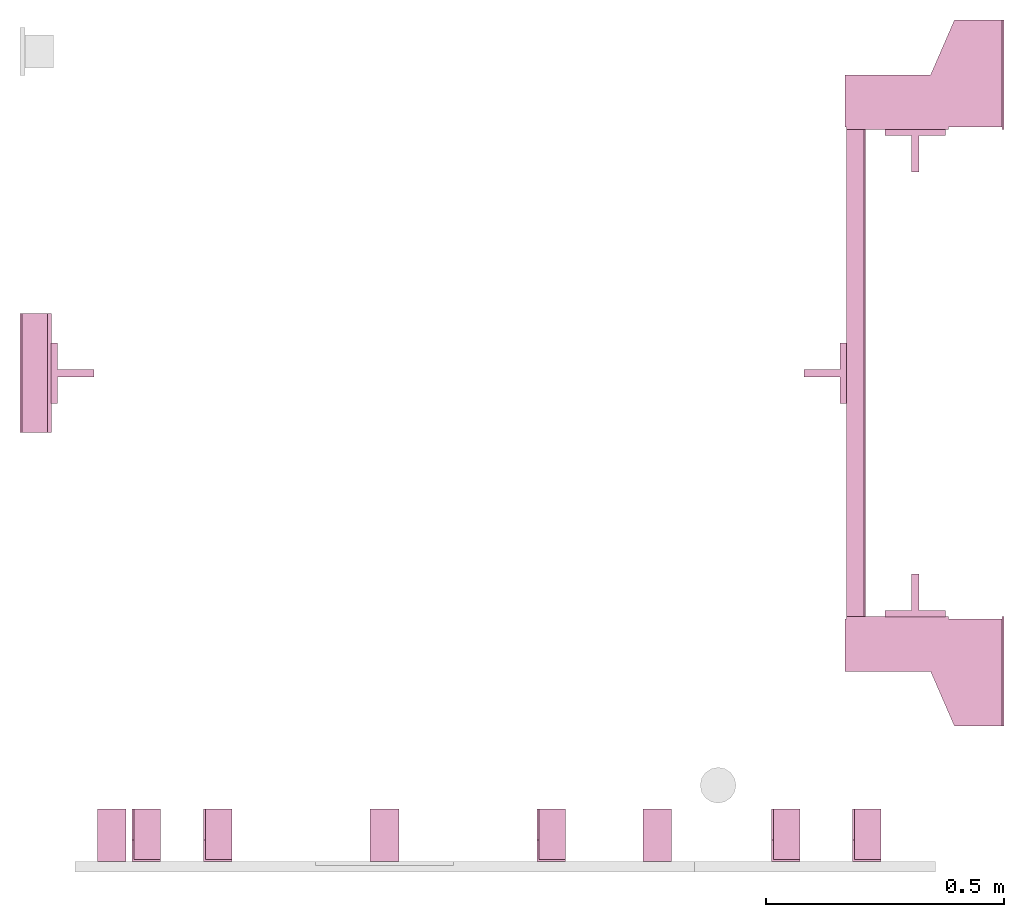
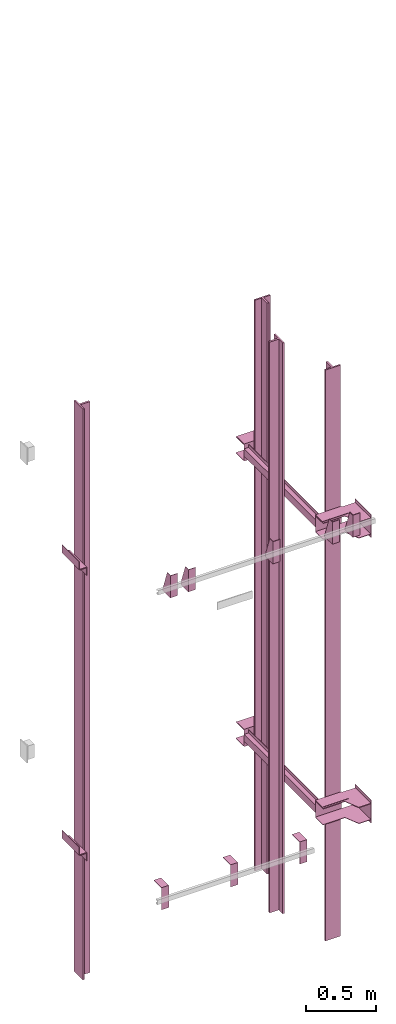
# One storey, part 3 of 3: 16 transport elements.
"""IFC4 building model written with IfcOpenShell, lengths in millimetres."""

import ifcopenshell
import ifcopenshell.guid

model = None  # the IFC model being written
_history = None  # IfcOwnerHistory: only IFC2X3 demands one
_inside = {}  # id of a spatial element -> (the spatial element, [elements in it])
_under = {}  # id of a project, library or spatial element -> (it, [spatial elements below it])
_declared = {}  # id of a project -> (the project, [libraries it declares])
_typed = {}  # id of a type object -> (the type object, [elements of that type])
_made_of = {}  # id of a material, layer set ... -> (it, [elements and type objects made of it])


def new_model(schema):
    """Start an empty IFC model of exactly this schema.

    Asked for "IFC4X3", IfcOpenShell would pick the latest addendum, in which some entities
    have other attributes; the version numbers below select the first issue.
    IFC2X3 requires an IfcOwnerHistory on every rooted entity: one is made here for all.
    """
    global model, _history
    if schema == "IFC4X3":
        model = ifcopenshell.file(schema_version=(4, 3, 0, 0))
    else:
        model = ifcopenshell.file(schema=schema)
    _inside.clear()
    _under.clear()
    _declared.clear()
    _typed.clear()
    _made_of.clear()
    _history = None
    if model.schema == "IFC2X3":
        org = make("IfcOrganization", Name="unknown")
        user = make(
            "IfcPersonAndOrganization",
            ThePerson=make("IfcPerson", FamilyName="unknown"),
            TheOrganization=org,
        )
        app = make(
            "IfcApplication",
            ApplicationDeveloper=org,
            Version="unknown",
            ApplicationFullName="unknown",
            ApplicationIdentifier="unknown",
        )
        _history = make(
            "IfcOwnerHistory",
            OwningUser=user,
            OwningApplication=app,
            ChangeAction="ADDED",
            CreationDate=0,
        )
    return model


def make(cls, **values):
    """One entity of the class cls with the attributes given. An attribute that is None is left unset."""
    return model.create_entity(
        cls, **{name: value for name, value in values.items() if value is not None}
    )


def entity(cls, *values):
    """Any entity or typed value of the class cls, its attributes in the order of the schema. None: left unset."""
    e = model.create_entity(cls)
    for i, value in enumerate(values):
        if value is not None:
            e[i] = value
    return e


def rooted(cls, **values):
    """An entity with a GlobalId (a new one), such as an element, a storey or a relation."""
    return make(cls, GlobalId=ifcopenshell.guid.new(), OwnerHistory=_history, **values)


def si_unit(unit_type, name, prefix=None):
    """IfcSIUnit, for example si_unit("LENGTHUNIT", "METRE", prefix="MILLI")."""
    return make("IfcSIUnit", UnitType=unit_type, Prefix=prefix, Name=name)


def converted_unit(unit_type, name, factor, base, dimensions=None, offset=None):
    """IfcConversionBasedUnit, such as the inch: factor (a typed value) times the base unit."""
    return make(
        "IfcConversionBasedUnit"
        if offset is None
        else "IfcConversionBasedUnitWithOffset",
        ConversionOffset=offset,
        Dimensions=None
        if dimensions is None
        else entity("IfcDimensionalExponents", *dimensions),
        UnitType=unit_type,
        Name=name,
        ConversionFactor=make(
            "IfcMeasureWithUnit", ValueComponent=factor, UnitComponent=base
        ),
    )


def assignment(units):
    """IfcUnitAssignment: the units of a project."""
    return None if units is None else make("IfcUnitAssignment", Units=units)


def point(xyz):
    """IfcCartesianPoint."""
    return None if xyz is None else make("IfcCartesianPoint", Coordinates=xyz)


def direction(xyz):
    """IfcDirection."""
    return None if xyz is None else make("IfcDirection", DirectionRatios=xyz)


def frame(location, z_axis=None, x_axis=None):
    """IfcAxis2Placement3D, a coordinate frame: its origin and axes. An axis left out is left unset."""
    return make(
        "IfcAxis2Placement3D",
        Location=point(location),
        Axis=direction(z_axis),
        RefDirection=direction(x_axis),
    )


def origin_with_axes():
    """The frame at (0, 0, 0) with the z axis (0, 0, 1) and the x axis (1, 0, 0) written out."""
    return frame((0.0, 0.0, 0.0), z_axis=(0.0, 0.0, 1.0), x_axis=(1.0, 0.0, 0.0))


def place(relative_to, where):
    """IfcLocalPlacement: puts the frame where relative to a parent placement (None: the world)."""
    return make(
        "IfcLocalPlacement", PlacementRelTo=relative_to, RelativePlacement=where
    )


def context(
    kind, dimensions, precision=None, world=None, true_north=None, identifier=None
):
    """IfcGeometricRepresentationContext, for example the 3D "Model" context."""
    return make(
        "IfcGeometricRepresentationContext",
        ContextIdentifier=identifier,
        ContextType=kind,
        CoordinateSpaceDimension=dimensions,
        Precision=precision,
        WorldCoordinateSystem=world,
        TrueNorth=true_north,
    )


def subcontext(parent, identifier, kind, view, scale=None):
    """IfcGeometricRepresentationSubContext, for example "Body" below "Model"."""
    return make(
        "IfcGeometricRepresentationSubContext",
        ContextIdentifier=identifier,
        ContextType=kind,
        ParentContext=parent,
        TargetScale=scale,
        TargetView=view,
    )


def project(units=None, contexts=None):
    """IfcProject with its units and contexts."""
    return rooted(
        "IfcProject",
        Name="project",
        RepresentationContexts=contexts,
        UnitsInContext=assignment(units),
    )


def spatial(cls, under=None, at=None, **own):
    """A site, building, storey or space (cls), placed at a placement, below another one or the project."""
    s = rooted(cls, ObjectPlacement=at, **own)
    if under is not None:
        _under.setdefault(under.id(), (under, []))[1].append(s)
    return s


def faces_of(points, faces, orient=None, outer=None):
    """IfcFace entities. A face is a list of loops; a loop is a list of indices into points, from 0.

    orient and outer hold one flag for each loop. By default every Orientation is true, the
    first loop of a face is its IfcFaceOuterBound and the others are IfcFaceBound.
    """
    made = []
    for i, loops in enumerate(faces):
        bounds = []
        for j, loop in enumerate(loops):
            is_outer = j == 0 if outer is None else outer[i][j]
            bounds.append(
                make(
                    "IfcFaceOuterBound" if is_outer else "IfcFaceBound",
                    Bound=make("IfcPolyLoop", Polygon=[points[k] for k in loop]),
                    Orientation=True if orient is None else orient[i][j],
                )
            )
        made.append(make("IfcFace", Bounds=bounds))
    return made


def faceted_brep(points, faces, orient=None, outer=None, voids=None):
    """IfcFacetedBrep: a solid bounded by flat faces; with voids (closed shells), ...WithVoids."""
    shared = [point(p) for p in points]
    hull = make("IfcClosedShell", CfsFaces=faces_of(shared, faces, orient, outer))
    if voids is None:
        return make("IfcFacetedBrep", Outer=hull)
    return make(
        "IfcFacetedBrepWithVoids",
        Outer=hull,
        Voids=[
            make(cls, CfsFaces=faces_of(shared, fs, o, b)) for cls, fs, o, b in voids
        ],
    )


def shape(context_of_items, identifier, shape_type, items):
    """IfcShapeRepresentation: the items that make up one representation, for example the "Body"."""
    return make(
        "IfcShapeRepresentation",
        ContextOfItems=context_of_items,
        RepresentationIdentifier=identifier,
        RepresentationType=shape_type,
        Items=items,
    )


def made_of(thing, what):
    """Note that an element or type object is made of a material, layer set ...; save() writes the relation."""
    if what is not None:
        _made_of.setdefault(what.id(), (what, []))[1].append(thing)
    return thing


def element(
    cls,
    number,
    at=None,
    inside=None,
    cuts=None,
    type_object=None,
    material=None,
    context=None,
    identifier="Body",
    shape_type=None,
    held_by="IfcProductDefinitionShape",
    body=None,
    shapes=None,
    **own,
):
    """One element of the class cls, such as IfcWall. Its Tag is "e" and its number.

    at: its placement. inside: the storey or other place that contains it. cuts: it is an
    opening in that element (IfcRelVoidsElement). A single representation is given by context,
    identifier, shape_type and body (its items); several are given by shapes. held_by: the class
    of the entity that holds the representations. save() writes the other relations.
    """
    e = rooted(cls, Tag="e%d" % number, ObjectPlacement=at, **own)
    if body is not None:
        shapes = [shape(context, identifier, shape_type, body)]
    if shapes is not None:
        e.Representation = make(held_by, Representations=shapes)
    if inside is not None:
        _inside.setdefault(inside.id(), (inside, []))[1].append(e)
    if cuts is not None:
        rooted(
            "IfcRelVoidsElement", RelatingBuildingElement=cuts, RelatedOpeningElement=e
        )
    if type_object is not None:
        _typed.setdefault(type_object.id(), (type_object, []))[1].append(e)
    return made_of(e, material)


def aggregate(whole, parts):
    """IfcRelAggregates: a whole, such as a stair, and the parts it consists of."""
    return rooted("IfcRelAggregates", RelatingObject=whole, RelatedObjects=parts)


def save(model, path):
    """Write the relations noted so far, then the file.

    IfcRelAggregates (storeys below a building ...), IfcRelContainedInSpatialStructure (elements
    in a storey), IfcRelDefinesByType, IfcRelAssociatesMaterial and IfcRelDeclares: one each for
    every whole, place, type object, material and project.
    """
    for whole, parts in _under.values():
        aggregate(whole, parts)
    for where, things in _inside.values():
        rooted(
            "IfcRelContainedInSpatialStructure",
            RelatedElements=things,
            RelatingStructure=where,
        )
    for kind, things in _typed.values():
        rooted("IfcRelDefinesByType", RelatedObjects=things, RelatingType=kind)
    for what, things in _made_of.values():
        rooted("IfcRelAssociatesMaterial", RelatedObjects=things, RelatingMaterial=what)
    for by, libraries in _declared.values():
        rooted("IfcRelDeclares", RelatingContext=by, RelatedDefinitions=libraries)
    model.write(path)


model = new_model("IFC4")

# Units and contexts
context_of_model = context(None, 3, precision=0.01, world=origin_with_axes())
sub_context_1 = subcontext(context_of_model, None, None, "MODEL_VIEW")
sub_context_2 = subcontext(context_of_model, None, None, "MODEL_VIEW")
sub_context_3 = subcontext(context_of_model, None, None, "MODEL_VIEW")
sub_context_4 = subcontext(context_of_model, None, None, "MODEL_VIEW")
sub_context_5 = subcontext(context_of_model, None, None, "MODEL_VIEW")
sub_context_6 = subcontext(context_of_model, None, None, "MODEL_VIEW")
sub_context_7 = subcontext(context_of_model, None, None, "MODEL_VIEW")
sub_context_8 = subcontext(context_of_model, None, None, "MODEL_VIEW")
sub_context_9 = subcontext(context_of_model, None, None, "MODEL_VIEW")
sub_context_10 = subcontext(context_of_model, None, None, "MODEL_VIEW")
sub_context_11 = subcontext(context_of_model, None, None, "MODEL_VIEW")
sub_context_12 = subcontext(context_of_model, None, None, "MODEL_VIEW")
sub_context_13 = subcontext(context_of_model, None, None, "MODEL_VIEW")
sub_context_14 = subcontext(context_of_model, None, None, "MODEL_VIEW")
sub_context_15 = subcontext(context_of_model, None, None, "MODEL_VIEW")
sub_context_16 = subcontext(context_of_model, None, None, "MODEL_VIEW")
ifc_project = project(units=[converted_unit("PLANEANGLEUNIT", "degree", entity("IfcPlaneAngleMeasure", 0.017453292519943), si_unit("PLANEANGLEUNIT", "RADIAN"), dimensions=[0, 0, 0, 0, 0, 0, 0]), si_unit("LENGTHUNIT", "METRE", prefix="MILLI"), si_unit("MASSUNIT", "GRAM", prefix="KILO"), converted_unit("TIMEUNIT", "year", entity("IfcTimeMeasure", 31557600.0), si_unit("TIMEUNIT", "SECOND"), dimensions=[0, 0, 1, 0, 0, 0, 0]), si_unit("THERMODYNAMICTEMPERATUREUNIT", "DEGREE_CELSIUS"), si_unit("AREAUNIT", "SQUARE_METRE"), si_unit("FORCEUNIT", "NEWTON"), si_unit("VOLUMEUNIT", "CUBIC_METRE"), si_unit("PRESSUREUNIT", "PASCAL"), si_unit("SOLIDANGLEUNIT", "STERADIAN")], contexts=[context_of_model])

# Site, building, storey
site = spatial("IfcSite", under=ifc_project)
building = spatial("IfcBuilding", under=site, Name="Document")
placement = place(None, origin_with_axes())
storey_placement = place(placement, origin_with_axes())
storey = spatial("IfcBuildingStorey", under=building, at=storey_placement, Name="0", Elevation=0.0)

# Transport elements
transport_element_1_placement = place(storey_placement, frame((2065.0, 1025.0, -200.0), z_axis=(0.0, 0.0, 1.0), x_axis=(0.0, 1.0, 0.0)))
element("IfcTransportElement", 1, at=transport_element_1_placement, inside=storey, PredefinedType="ELEVATOR", context=sub_context_1, shape_type="Brep", body=[
    faceted_brep([(-611.0, 331.0, -72.5), (-514.0, 331.0, -72.5), (-514.0, 331.0, 72.5), (-611.0, 331.0, 72.5), (-611.0, 331.0, 75.5), (-511.0, 331.0, 75.5), (-511.0, 331.0, -75.5), (-611.0, 331.0, -75.5), (-511.0, 116.0, -75.5), (-511.0, 116.0, 75.5), (-611.0, 116.0, 75.5), (-611.0, 116.0, 72.5), (-514.0, 116.0, 72.5), (-514.0, 116.0, -72.5), (-611.0, 116.0, -72.5), (-611.0, 116.0, -75.5)], [[[0, 1, 2, 3, 4, 5, 6, 7]], [[8, 9, 10, 11, 12, 13, 14, 15]], [[15, 14, 0, 7]], [[13, 12, 2, 1]], [[5, 9, 8, 6]], [[11, 10, 4, 3]], [[6, 8, 15, 7]], [[14, 13, 1, 0]], [[2, 12, 11, 3]], [[10, 9, 5, 4]]]),
    faceted_brep([(-511.0, 331.0, 32.5), (511.0, 331.0, 32.5), (511.0, 331.0, -32.5), (-511.0, 331.0, -32.5), (511.0, 328.0, -29.5), (511.0, 328.0, 29.5), (-511.0, 328.0, 29.5), (-511.0, 328.0, -29.5), (511.0, 291.0, -32.5), (511.0, 291.0, -29.5), (-511.0, 291.0, -29.5), (-511.0, 291.0, -32.5), (511.0, 291.0, 29.5), (511.0, 291.0, 32.5), (-511.0, 291.0, 32.5), (-511.0, 291.0, 29.5)], [[[0, 1, 2, 3]], [[4, 5, 6, 7]], [[8, 9, 10, 11]], [[12, 13, 14, 15]], [[11, 10, 7, 6, 15, 14, 0, 3]], [[2, 1, 13, 12, 5, 4, 9, 8]], [[2, 8, 11, 3]], [[10, 9, 4, 7]], [[14, 13, 1, 0]], [[5, 12, 15, 6]]]),
    faceted_brep([(-511.0, 291.0, -32.5), (-511.0, 294.0, -32.5), (-511.0, 294.0, -59.5), (-511.0, 291.0, -59.5), (511.0, 291.0, -32.5), (511.0, 291.0, -59.5), (511.0, 294.0, -59.5), (511.0, 294.0, -32.5)], [[[0, 1, 2, 3]], [[4, 5, 6, 7]], [[0, 3, 5, 4]], [[3, 2, 6, 5]], [[2, 1, 7, 6]], [[1, 0, 4, 7]]]),
    faceted_brep([(-511.0, 291.0, 59.5), (-511.0, 294.0, 59.5), (-511.0, 294.0, 32.5), (-511.0, 291.0, 32.5), (511.0, 291.0, 59.5), (511.0, 291.0, 32.5), (511.0, 294.0, 32.5), (511.0, 294.0, 59.5)], [[[0, 1, 2, 3]], [[4, 5, 6, 7]], [[0, 3, 5, 4]], [[3, 2, 6, 5]], [[2, 1, 7, 6]], [[1, 0, 4, 7]]]),
    faceted_brep([(-626.0, 334.0, 72.5), (-516.0, 334.0, 72.5), (-516.0, 334.0, 68.5), (-626.0, 334.0, 68.5), (-516.0, 4.0, 68.5), (-516.0, 4.0, 72.5), (-741.0, 4.0, 72.5), (-741.0, 4.0, 68.5), (-741.0, 104.0, 72.5), (-626.0, 154.0, 72.5), (-626.0, 154.0, 68.5), (-741.0, 104.0, 68.5)], [[[0, 1, 2, 3]], [[4, 5, 6, 7]], [[8, 9, 10, 11]], [[10, 9, 0, 3]], [[1, 5, 4, 2]], [[7, 6, 8, 11]], [[2, 4, 7, 11, 10, 3]], [[9, 8, 6, 5, 1, 0]]]),
    faceted_brep([(516.0, 334.0, -68.5), (626.0, 334.0, -68.5), (626.0, 334.0, -72.5), (516.0, 334.0, -72.5), (741.0, 4.0, -72.5), (741.0, 4.0, -68.5), (516.0, 4.0, -68.5), (516.0, 4.0, -72.5), (626.0, 154.0, -68.5), (741.0, 104.0, -68.5), (741.0, 104.0, -72.5), (626.0, 154.0, -72.5)], [[[0, 1, 2, 3]], [[4, 5, 6, 7]], [[8, 9, 10, 11]], [[7, 6, 0, 3]], [[1, 8, 11, 2]], [[9, 5, 4, 10]], [[2, 11, 10, 4, 7, 3]], [[6, 5, 9, 8, 1, 0]]]),
    faceted_brep([(516.0, 334.0, 72.5), (626.0, 334.0, 72.5), (626.0, 334.0, 68.5), (516.0, 334.0, 68.5), (741.0, 4.0, 68.5), (741.0, 4.0, 72.5), (516.0, 4.0, 72.5), (516.0, 4.0, 68.5), (626.0, 154.0, 72.5), (741.0, 104.0, 72.5), (741.0, 104.0, 68.5), (626.0, 154.0, 68.5)], [[[0, 1, 2, 3]], [[4, 5, 6, 7]], [[8, 9, 10, 11]], [[7, 6, 0, 3]], [[1, 8, 11, 2]], [[9, 5, 4, 10]], [[2, 11, 10, 4, 7, 3]], [[6, 5, 9, 8, 1, 0]]]),
    faceted_brep([(511.0, 331.0, 75.5), (611.0, 331.0, 75.5), (611.0, 331.0, 72.5), (514.0, 331.0, 72.5), (514.0, 331.0, -72.5), (611.0, 331.0, -72.5), (611.0, 331.0, -75.5), (511.0, 331.0, -75.5), (511.0, 116.0, -75.5), (611.0, 116.0, -75.5), (611.0, 116.0, -72.5), (514.0, 116.0, -72.5), (514.0, 116.0, 72.5), (611.0, 116.0, 72.5), (611.0, 116.0, 75.5), (511.0, 116.0, 75.5)], [[[0, 1, 2, 3, 4, 5, 6, 7]], [[8, 9, 10, 11, 12, 13, 14, 15]], [[8, 15, 0, 7]], [[3, 12, 11, 4]], [[5, 10, 9, 6]], [[1, 14, 13, 2]], [[6, 9, 8, 7]], [[11, 10, 5, 4]], [[15, 14, 1, 0]], [[2, 13, 12, 3]]]),
    faceted_brep([(-626.0, 334.0, -68.5), (-516.0, 334.0, -68.5), (-516.0, 334.0, -72.5), (-626.0, 334.0, -72.5), (-516.0, 4.0, -72.5), (-516.0, 4.0, -68.5), (-741.0, 4.0, -68.5), (-741.0, 4.0, -72.5), (-741.0, 104.0, -68.5), (-626.0, 154.0, -68.5), (-626.0, 154.0, -72.5), (-741.0, 104.0, -72.5)], [[[0, 1, 2, 3]], [[4, 5, 6, 7]], [[8, 9, 10, 11]], [[10, 9, 0, 3]], [[1, 5, 4, 2]], [[7, 6, 8, 11]], [[2, 4, 7, 11, 10, 3]], [[9, 8, 6, 5, 1, 0]]]),
    faceted_brep([(741.0, 0.0, -100.0), (741.0, 0.0, 100.0), (511.0, 0.0, 100.0), (511.0, 0.0, -100.0), (741.0, 4.0, -100.0), (511.0, 4.0, -100.0), (511.0, 4.0, 100.0), (741.0, 4.0, 100.0)], [[[0, 1, 2, 3]], [[4, 5, 6, 7]], [[0, 3, 5, 4]], [[3, 2, 6, 5]], [[2, 1, 7, 6]], [[1, 0, 4, 7]]]),
    faceted_brep([(-511.0, 0.0, -100.0), (-511.0, 0.0, 100.0), (-741.0, 0.0, 100.0), (-741.0, 0.0, -100.0), (-511.0, 4.0, -100.0), (-741.0, 4.0, -100.0), (-741.0, 4.0, 100.0), (-511.0, 4.0, 100.0)], [[[0, 1, 2, 3]], [[4, 5, 6, 7]], [[0, 3, 5, 4]], [[3, 2, 6, 5]], [[2, 1, 7, 6]], [[1, 0, 4, 7]]]),
])
transport_element_2_placement = place(storey_placement, frame((2065.0, 1025.0, 2300.0), z_axis=(0.0, 0.0, 1.0), x_axis=(0.0, 1.0, 0.0)))
element("IfcTransportElement", 2, at=transport_element_2_placement, inside=storey, PredefinedType="ELEVATOR", context=sub_context_2, shape_type="Brep", body=[
    faceted_brep([(-511.0, 331.0, 32.5), (511.0, 331.0, 32.5), (511.0, 331.0, -32.5), (-511.0, 331.0, -32.5), (511.0, 328.0, -29.5), (511.0, 328.0, 29.5), (-511.0, 328.0, 29.5), (-511.0, 328.0, -29.5), (511.0, 291.0, -32.5), (511.0, 291.0, -29.5), (-511.0, 291.0, -29.5), (-511.0, 291.0, -32.5), (511.0, 291.0, 29.5), (511.0, 291.0, 32.5), (-511.0, 291.0, 32.5), (-511.0, 291.0, 29.5)], [[[0, 1, 2, 3]], [[4, 5, 6, 7]], [[8, 9, 10, 11]], [[12, 13, 14, 15]], [[11, 10, 7, 6, 15, 14, 0, 3]], [[2, 1, 13, 12, 5, 4, 9, 8]], [[2, 8, 11, 3]], [[10, 9, 4, 7]], [[14, 13, 1, 0]], [[5, 12, 15, 6]]]),
    faceted_brep([(-511.0, 291.0, -32.5), (-511.0, 294.0, -32.5), (-511.0, 294.0, -59.5), (-511.0, 291.0, -59.5), (511.0, 291.0, -32.5), (511.0, 291.0, -59.5), (511.0, 294.0, -59.5), (511.0, 294.0, -32.5)], [[[0, 1, 2, 3]], [[4, 5, 6, 7]], [[0, 3, 5, 4]], [[3, 2, 6, 5]], [[2, 1, 7, 6]], [[1, 0, 4, 7]]]),
    faceted_brep([(-611.0, 331.0, -72.5), (-514.0, 331.0, -72.5), (-514.0, 331.0, 72.5), (-611.0, 331.0, 72.5), (-611.0, 331.0, 75.5), (-511.0, 331.0, 75.5), (-511.0, 331.0, -75.5), (-611.0, 331.0, -75.5), (-511.0, 116.0, -75.5), (-511.0, 116.0, 75.5), (-611.0, 116.0, 75.5), (-611.0, 116.0, 72.5), (-514.0, 116.0, 72.5), (-514.0, 116.0, -72.5), (-611.0, 116.0, -72.5), (-611.0, 116.0, -75.5)], [[[0, 1, 2, 3, 4, 5, 6, 7]], [[8, 9, 10, 11, 12, 13, 14, 15]], [[15, 14, 0, 7]], [[13, 12, 2, 1]], [[5, 9, 8, 6]], [[11, 10, 4, 3]], [[6, 8, 15, 7]], [[14, 13, 1, 0]], [[2, 12, 11, 3]], [[10, 9, 5, 4]]]),
    faceted_brep([(-511.0, 291.0, 59.5), (-511.0, 294.0, 59.5), (-511.0, 294.0, 32.5), (-511.0, 291.0, 32.5), (511.0, 291.0, 59.5), (511.0, 291.0, 32.5), (511.0, 294.0, 32.5), (511.0, 294.0, 59.5)], [[[0, 1, 2, 3]], [[4, 5, 6, 7]], [[0, 3, 5, 4]], [[3, 2, 6, 5]], [[2, 1, 7, 6]], [[1, 0, 4, 7]]]),
    faceted_brep([(516.0, 334.0, -68.5), (626.0, 334.0, -68.5), (626.0, 334.0, -72.5), (516.0, 334.0, -72.5), (741.0, 4.0, -72.5), (741.0, 4.0, -68.5), (516.0, 4.0, -68.5), (516.0, 4.0, -72.5), (626.0, 154.0, -68.5), (741.0, 104.0, -68.5), (741.0, 104.0, -72.5), (626.0, 154.0, -72.5)], [[[0, 1, 2, 3]], [[4, 5, 6, 7]], [[8, 9, 10, 11]], [[7, 6, 0, 3]], [[1, 8, 11, 2]], [[9, 5, 4, 10]], [[2, 11, 10, 4, 7, 3]], [[6, 5, 9, 8, 1, 0]]]),
    faceted_brep([(511.0, 331.0, 75.5), (611.0, 331.0, 75.5), (611.0, 331.0, 72.5), (514.0, 331.0, 72.5), (514.0, 331.0, -72.5), (611.0, 331.0, -72.5), (611.0, 331.0, -75.5), (511.0, 331.0, -75.5), (511.0, 116.0, -75.5), (611.0, 116.0, -75.5), (611.0, 116.0, -72.5), (514.0, 116.0, -72.5), (514.0, 116.0, 72.5), (611.0, 116.0, 72.5), (611.0, 116.0, 75.5), (511.0, 116.0, 75.5)], [[[0, 1, 2, 3, 4, 5, 6, 7]], [[8, 9, 10, 11, 12, 13, 14, 15]], [[8, 15, 0, 7]], [[3, 12, 11, 4]], [[5, 10, 9, 6]], [[1, 14, 13, 2]], [[6, 9, 8, 7]], [[11, 10, 5, 4]], [[15, 14, 1, 0]], [[2, 13, 12, 3]]]),
    faceted_brep([(-626.0, 334.0, 72.5), (-516.0, 334.0, 72.5), (-516.0, 334.0, 68.5), (-626.0, 334.0, 68.5), (-516.0, 4.0, 68.5), (-516.0, 4.0, 72.5), (-741.0, 4.0, 72.5), (-741.0, 4.0, 68.5), (-741.0, 104.0, 72.5), (-626.0, 154.0, 72.5), (-626.0, 154.0, 68.5), (-741.0, 104.0, 68.5)], [[[0, 1, 2, 3]], [[4, 5, 6, 7]], [[8, 9, 10, 11]], [[10, 9, 0, 3]], [[1, 5, 4, 2]], [[7, 6, 8, 11]], [[2, 4, 7, 11, 10, 3]], [[9, 8, 6, 5, 1, 0]]]),
    faceted_brep([(516.0, 334.0, 72.5), (626.0, 334.0, 72.5), (626.0, 334.0, 68.5), (516.0, 334.0, 68.5), (741.0, 4.0, 68.5), (741.0, 4.0, 72.5), (516.0, 4.0, 72.5), (516.0, 4.0, 68.5), (626.0, 154.0, 72.5), (741.0, 104.0, 72.5), (741.0, 104.0, 68.5), (626.0, 154.0, 68.5)], [[[0, 1, 2, 3]], [[4, 5, 6, 7]], [[8, 9, 10, 11]], [[7, 6, 0, 3]], [[1, 8, 11, 2]], [[9, 5, 4, 10]], [[2, 11, 10, 4, 7, 3]], [[6, 5, 9, 8, 1, 0]]]),
    faceted_brep([(-626.0, 334.0, -68.5), (-516.0, 334.0, -68.5), (-516.0, 334.0, -72.5), (-626.0, 334.0, -72.5), (-516.0, 4.0, -72.5), (-516.0, 4.0, -68.5), (-741.0, 4.0, -68.5), (-741.0, 4.0, -72.5), (-741.0, 104.0, -68.5), (-626.0, 154.0, -68.5), (-626.0, 154.0, -72.5), (-741.0, 104.0, -72.5)], [[[0, 1, 2, 3]], [[4, 5, 6, 7]], [[8, 9, 10, 11]], [[10, 9, 0, 3]], [[1, 5, 4, 2]], [[7, 6, 8, 11]], [[2, 4, 7, 11, 10, 3]], [[9, 8, 6, 5, 1, 0]]]),
    faceted_brep([(-511.0, 0.0, -100.0), (-511.0, 0.0, 100.0), (-741.0, 0.0, 100.0), (-741.0, 0.0, -100.0), (-511.0, 4.0, -100.0), (-741.0, 4.0, -100.0), (-741.0, 4.0, 100.0), (-511.0, 4.0, 100.0)], [[[0, 1, 2, 3]], [[4, 5, 6, 7]], [[0, 3, 5, 4]], [[3, 2, 6, 5]], [[2, 1, 7, 6]], [[1, 0, 4, 7]]]),
    faceted_brep([(741.0, 0.0, -100.0), (741.0, 0.0, 100.0), (511.0, 0.0, 100.0), (511.0, 0.0, -100.0), (741.0, 4.0, -100.0), (511.0, 4.0, -100.0), (511.0, 4.0, 100.0), (741.0, 4.0, 100.0)], [[[0, 1, 2, 3]], [[4, 5, 6, 7]], [[0, 3, 5, 4]], [[3, 2, 6, 5]], [[2, 1, 7, 6]], [[1, 0, 4, 7]]]),
])
transport_element_3_placement = place(storey_placement, frame((1879.0, 558.5, 1113.0), z_axis=(0.0, -1.0, 0.0), x_axis=(0.0, 0.0, -1.0)))
element("IfcTransportElement", 3, at=transport_element_3_placement, inside=storey, ObjectType="Guide Rail", PredefinedType="ELEVATOR", context=sub_context_3, shape_type="Brep", body=[
    faceted_brep([(-2500.0, -63.5, 45.0), (-2500.0, 63.5, 45.0), (-2500.0, 63.5, 44.0), (-2500.0, -63.5, 44.0), (-2347.5, -63.5, 45.0), (-2347.5, -63.5, 44.0), (-2347.5, 63.5, 44.0), (-2347.5, 63.5, 45.0)], [[[0, 1, 2, 3]], [[4, 5, 6, 7]], [[0, 3, 5, 4]], [[3, 2, 6, 5]], [[2, 1, 7, 6]], [[1, 0, 4, 7]]]),
    faceted_brep([(2347.5, -63.5, 45.0), (2347.5, 63.5, 45.0), (2347.5, 63.5, 44.0), (2347.5, -63.5, 44.0), (2500.0, -63.5, 45.0), (2500.0, -63.5, 44.0), (2500.0, 63.5, 44.0), (2500.0, 63.5, 45.0)], [[[0, 1, 2, 3]], [[4, 5, 6, 7]], [[0, 3, 5, 4]], [[3, 2, 6, 5]], [[2, 1, 7, 6]], [[1, 0, 4, 7]]]),
    faceted_brep([(-2500.0, -63.5, 44.5), (-2500.0, -63.5, 31.79998779296875), (2500.0, -63.5, 31.79998779296875), (2500.0, -63.5, 44.5), (-2500.0, -7.93994140625, 31.79998779296875), (-2500.0, -7.93994140625, -44.5), (2500.0, -7.93994140625, -44.5), (2500.0, -7.93994140625, 31.79998779296875), (2500.0, 7.93994140625, -44.5), (-2500.0, 7.93994140625, -44.5), (-2500.0, 7.93994140625, 31.79998779296875), (2500.0, 7.93994140625, 31.79998779296875), (2500.0, 63.5, 31.79998779296875), (-2500.0, 63.5, 31.79998779296875), (-2500.0, 63.5, 44.5), (2500.0, 63.5, 44.5)], [[[0, 1, 2, 3]], [[4, 5, 6, 7]], [[8, 9, 10, 11]], [[12, 13, 14, 15]], [[15, 14, 0, 3]], [[1, 4, 7, 2]], [[10, 13, 12, 11]], [[5, 9, 8, 6]], [[2, 7, 6, 8, 11, 12, 15, 3]], [[14, 13, 10, 9, 5, 4, 1, 0]]]),
])
transport_element_4_placement = place(storey_placement, frame((1879.0, 1491.5, 1113.0), z_axis=(0.0, 1.0, 0.0), x_axis=(0.0, 0.0, 1.0)))
element("IfcTransportElement", 4, at=transport_element_4_placement, inside=storey, ObjectType="Guide Rail", PredefinedType="ELEVATOR", context=sub_context_4, shape_type="Brep", body=[
    faceted_brep([(2347.5, -63.5, 45.0), (2347.5, 63.5, 45.0), (2347.5, 63.5, 44.0), (2347.5, -63.5, 44.0), (2500.0, -63.5, 45.0), (2500.0, -63.5, 44.0), (2500.0, 63.5, 44.0), (2500.0, 63.5, 45.0)], [[[0, 1, 2, 3]], [[4, 5, 6, 7]], [[0, 3, 5, 4]], [[3, 2, 6, 5]], [[2, 1, 7, 6]], [[1, 0, 4, 7]]]),
    faceted_brep([(-2500.0, -63.5, 45.0), (-2500.0, 63.5, 45.0), (-2500.0, 63.5, 44.0), (-2500.0, -63.5, 44.0), (-2347.5, -63.5, 45.0), (-2347.5, -63.5, 44.0), (-2347.5, 63.5, 44.0), (-2347.5, 63.5, 45.0)], [[[0, 1, 2, 3]], [[4, 5, 6, 7]], [[0, 3, 5, 4]], [[3, 2, 6, 5]], [[2, 1, 7, 6]], [[1, 0, 4, 7]]]),
    faceted_brep([(2500.0, -63.5, 31.800048828125), (2500.0, -63.5, 44.5), (-2500.0, -63.5, 44.5), (-2500.0, -63.5, 31.800048828125), (2500.0, -7.93994140625, -44.5), (2500.0, -7.93994140625, 31.800048828125), (-2500.0, -7.93994140625, 31.800048828125), (-2500.0, -7.93994140625, -44.5), (-2500.0, 7.93994140625, 31.800048828125), (2500.0, 7.93994140625, 31.800048828125), (2500.0, 7.93994140625, -44.5), (-2500.0, 7.93994140625, -44.5), (-2500.0, 63.5, 44.5), (2500.0, 63.5, 44.5), (2500.0, 63.5, 31.800048828125), (-2500.0, 63.5, 31.800048828125)], [[[0, 1, 2, 3]], [[4, 5, 6, 7]], [[8, 9, 10, 11]], [[12, 13, 14, 15]], [[6, 5, 0, 3]], [[1, 13, 12, 2]], [[11, 10, 4, 7]], [[9, 8, 15, 14]], [[2, 12, 15, 8, 11, 7, 6, 3]], [[5, 4, 10, 9, 14, 13, 1, 0]]]),
])
transport_element_5_placement = place(storey_placement, frame((110.5, 1025.0, 1113.0), z_axis=(-1.0, 0.0, 0.0), x_axis=(0.0, 0.0, -1.0)))
element("IfcTransportElement", 5, at=transport_element_5_placement, inside=storey, ObjectType="Guide Rail", PredefinedType="ELEVATOR", context=sub_context_5, shape_type="Brep", body=[
    faceted_brep([(2347.5, -63.5, 45.0), (2347.5, 63.5, 45.0), (2347.5, 63.5, 44.0), (2347.5, -63.5, 44.0), (2500.0, -63.5, 45.0), (2500.0, -63.5, 44.0), (2500.0, 63.5, 44.0), (2500.0, 63.5, 45.0)], [[[0, 1, 2, 3]], [[4, 5, 6, 7]], [[0, 3, 5, 4]], [[3, 2, 6, 5]], [[2, 1, 7, 6]], [[1, 0, 4, 7]]]),
    faceted_brep([(-2500.0, -63.5, 45.0), (-2500.0, 63.5, 45.0), (-2500.0, 63.5, 44.0), (-2500.0, -63.5, 44.0), (-2347.5, -63.5, 45.0), (-2347.5, -63.5, 44.0), (-2347.5, 63.5, 44.0), (-2347.5, 63.5, 45.0)], [[[0, 1, 2, 3]], [[4, 5, 6, 7]], [[0, 3, 5, 4]], [[3, 2, 6, 5]], [[2, 1, 7, 6]], [[1, 0, 4, 7]]]),
    faceted_brep([(-2500.0, 63.5, 44.5), (-2500.0, -63.5, 44.5), (2500.0, -63.5, 44.5), (2500.0, 63.5, 44.5), (2500.0, 7.94000244140625, 31.800003051757812), (-2500.0, 7.94000244140625, 31.800003051757812), (-2500.0, 63.5, 31.79998779296875), (2500.0, 63.5, 31.79998779296875), (2500.0, -63.5, 31.79998779296875), (-2500.0, -63.5, 31.79998779296875), (-2500.0, -7.93994140625, 31.79998779296875), (2500.0, -7.93994140625, 31.79998779296875), (2500.0, -7.93994140625, -44.5), (-2500.0, -7.93994140625, -44.5), (-2500.0, 7.94000244140625, -44.5), (2500.0, 7.94000244140625, -44.5)], [[[0, 1, 2, 3]], [[4, 5, 6, 7]], [[8, 9, 10, 11]], [[12, 13, 14, 15]], [[7, 6, 0, 3]], [[15, 14, 5, 4]], [[10, 13, 12, 11]], [[1, 9, 8, 2]], [[2, 8, 11, 12, 15, 4, 7, 3]], [[6, 5, 14, 13, 10, 9, 1, 0]]]),
])
transport_element_6_placement = place(storey_placement, frame((1689.5, 1025.0, 1113.0), z_axis=(1.0, 0.0, 0.0), x_axis=(0.0, 0.0, 1.0)))
element("IfcTransportElement", 6, at=transport_element_6_placement, inside=storey, ObjectType="Guide Rail", PredefinedType="ELEVATOR", context=sub_context_6, shape_type="Brep", body=[
    faceted_brep([(2347.5, -63.5, 45.0), (2347.5, 63.5, 45.0), (2347.5, 63.5, 44.0), (2347.5, -63.5, 44.0), (2500.0, -63.5, 45.0), (2500.0, -63.5, 44.0), (2500.0, 63.5, 44.0), (2500.0, 63.5, 45.0)], [[[0, 1, 2, 3]], [[4, 5, 6, 7]], [[0, 3, 5, 4]], [[3, 2, 6, 5]], [[2, 1, 7, 6]], [[1, 0, 4, 7]]]),
    faceted_brep([(-2500.0, -63.5, 45.0), (-2500.0, 63.5, 45.0), (-2500.0, 63.5, 44.0), (-2500.0, -63.5, 44.0), (-2347.5, -63.5, 45.0), (-2347.5, -63.5, 44.0), (-2347.5, 63.5, 44.0), (-2347.5, 63.5, 45.0)], [[[0, 1, 2, 3]], [[4, 5, 6, 7]], [[0, 3, 5, 4]], [[3, 2, 6, 5]], [[2, 1, 7, 6]], [[1, 0, 4, 7]]]),
    faceted_brep([(2500.0, 7.94000244140625, -44.5), (2500.0, -7.93994140625, -44.5), (-2500.0, -7.93994140625, -44.5), (-2500.0, 7.94000244140625, -44.5), (2500.0, 63.5, 31.800048828125), (2500.0, 7.94000244140625, 31.800048828125), (-2500.0, 7.94000244140625, 31.800048828125), (-2500.0, 63.5, 31.800048828125), (-2500.0, -63.5, 44.5), (2500.0, -63.5, 44.5), (2500.0, 63.5, 44.5), (-2500.0, 63.5, 44.5), (2500.0, -7.93994140625, 31.800048828125), (2500.0, -63.5, 31.800048828125), (-2500.0, -63.5, 31.800048828125), (-2500.0, -7.93994140625, 31.800048828125)], [[[0, 1, 2, 3]], [[4, 5, 6, 7]], [[8, 9, 10, 11]], [[12, 13, 14, 15]], [[6, 5, 0, 3]], [[1, 12, 15, 2]], [[11, 10, 4, 7]], [[13, 9, 8, 14]], [[2, 15, 14, 8, 11, 7, 6, 3]], [[5, 4, 10, 9, 13, 12, 1, 0]]]),
])
transport_element_7_placement = place(storey_placement, frame((265.0, 0.0, 2580.0), z_axis=(0.0, 0.0, 1.0), x_axis=(1.0, 0.0, 0.0)))
element("IfcTransportElement", 7, at=transport_element_7_placement, inside=storey, PredefinedType="ELEVATOR", context=sub_context_7, shape_type="Brep", body=[
    faceted_brep([(-30.0, 0.0, -97.0), (-30.0, 0.0, 97.0), (-30.0, 4.0, 97.0), (-30.0, 4.0, -93.0), (-30.0, 110.0, -93.0), (-30.0, 110.0, -97.0), (30.0, 110.0, -97.0), (30.0, 110.0, -93.0), (30.0, 4.0, -93.0), (30.0, 4.0, 97.0), (30.0, 0.0, 97.0), (30.0, 0.0, -97.0)], [[[0, 1, 2, 3, 4, 5]], [[6, 7, 8, 9, 10, 11]], [[11, 10, 1, 0]], [[2, 9, 8, 3]], [[4, 7, 6, 5]], [[5, 6, 11, 0]], [[8, 7, 4, 3]], [[10, 9, 2, 1]]]),
    faceted_brep([(-30.0, 4.0, -93.0), (-30.0, 4.0, 97.0), (-30.0, 45.0, 97.0), (-30.0, 110.0, -82.0), (-30.0, 110.0, -93.0), (-26.0, 4.0, -93.0), (-26.0, 110.0, -93.0), (-26.0, 110.0, -82.0), (-26.0, 45.0, 97.0), (-26.0, 4.0, 97.0)], [[[0, 1, 2, 3, 4]], [[5, 6, 7, 8, 9]], [[5, 0, 4, 6]], [[6, 4, 3, 7]], [[7, 3, 2, 8]], [[8, 2, 1, 9]], [[9, 1, 0, 5]]]),
])
transport_element_8_placement = place(storey_placement, frame((415.0, 0.0, 2580.0), z_axis=(0.0, 0.0, 1.0), x_axis=(1.0, 0.0, 0.0)))
element("IfcTransportElement", 8, at=transport_element_8_placement, inside=storey, PredefinedType="ELEVATOR", context=sub_context_8, shape_type="Brep", body=[
    faceted_brep([(-30.0, 4.0, -93.0), (-30.0, 4.0, 97.0), (-30.0, 45.0, 97.0), (-30.0, 110.0, -82.0), (-30.0, 110.0, -93.0), (-26.0, 4.0, -93.0), (-26.0, 110.0, -93.0), (-26.0, 110.0, -82.0), (-26.0, 45.0, 97.0), (-26.0, 4.0, 97.0)], [[[0, 1, 2, 3, 4]], [[5, 6, 7, 8, 9]], [[5, 0, 4, 6]], [[6, 4, 3, 7]], [[7, 3, 2, 8]], [[8, 2, 1, 9]], [[9, 1, 0, 5]]]),
    faceted_brep([(-30.0, 0.0, -97.0), (-30.0, 0.0, 97.0), (-30.0, 4.0, 97.0), (-30.0, 4.0, -93.0), (-30.0, 110.0, -93.0), (-30.0, 110.0, -97.0), (30.0, 110.0, -97.0), (30.0, 110.0, -93.0), (30.0, 4.0, -93.0), (30.0, 4.0, 97.0), (30.0, 0.0, 97.0), (30.0, 0.0, -97.0)], [[[0, 1, 2, 3, 4, 5]], [[6, 7, 8, 9, 10, 11]], [[11, 10, 1, 0]], [[2, 9, 8, 3]], [[4, 7, 6, 5]], [[5, 6, 11, 0]], [[8, 7, 4, 3]], [[10, 9, 2, 1]]]),
])
transport_element_9_placement = place(storey_placement, frame((1115.0, 0.0, 2580.0), z_axis=(0.0, 0.0, 1.0), x_axis=(1.0, 0.0, 0.0)))
element("IfcTransportElement", 9, at=transport_element_9_placement, inside=storey, PredefinedType="ELEVATOR", context=sub_context_9, shape_type="Brep", body=[
    faceted_brep([(-30.0, 4.0, -93.0), (-30.0, 4.0, 97.0), (-30.0, 45.0, 97.0), (-30.0, 110.0, -82.0), (-30.0, 110.0, -93.0), (-26.0, 4.0, -93.0), (-26.0, 110.0, -93.0), (-26.0, 110.0, -82.0), (-26.0, 45.0, 97.0), (-26.0, 4.0, 97.0)], [[[0, 1, 2, 3, 4]], [[5, 6, 7, 8, 9]], [[5, 0, 4, 6]], [[6, 4, 3, 7]], [[7, 3, 2, 8]], [[8, 2, 1, 9]], [[9, 1, 0, 5]]]),
    faceted_brep([(-30.0, 0.0, -97.0), (-30.0, 0.0, 97.0), (-30.0, 4.0, 97.0), (-30.0, 4.0, -93.0), (-30.0, 110.0, -93.0), (-30.0, 110.0, -97.0), (30.0, 110.0, -97.0), (30.0, 110.0, -93.0), (30.0, 4.0, -93.0), (30.0, 4.0, 97.0), (30.0, 0.0, 97.0), (30.0, 0.0, -97.0)], [[[0, 1, 2, 3, 4, 5]], [[6, 7, 8, 9, 10, 11]], [[11, 10, 1, 0]], [[2, 9, 8, 3]], [[4, 7, 6, 5]], [[5, 6, 11, 0]], [[8, 7, 4, 3]], [[10, 9, 2, 1]]]),
])
transport_element_10_placement = place(storey_placement, frame((1607.0, 0.0, 2580.0), z_axis=(0.0, 0.0, 1.0), x_axis=(1.0, 0.0, 0.0)))
element("IfcTransportElement", 10, at=transport_element_10_placement, inside=storey, PredefinedType="ELEVATOR", context=sub_context_10, shape_type="Brep", body=[
    faceted_brep([(-30.0, 0.0, -97.0), (-30.0, 0.0, 97.0), (-30.0, 4.0, 97.0), (-30.0, 4.0, -93.0), (-30.0, 110.0, -93.0), (-30.0, 110.0, -97.0), (30.0, 110.0, -97.0), (30.0, 110.0, -93.0), (30.0, 4.0, -93.0), (30.0, 4.0, 97.0), (30.0, 0.0, 97.0), (30.0, 0.0, -97.0)], [[[0, 1, 2, 3, 4, 5]], [[6, 7, 8, 9, 10, 11]], [[11, 10, 1, 0]], [[2, 9, 8, 3]], [[4, 7, 6, 5]], [[5, 6, 11, 0]], [[8, 7, 4, 3]], [[10, 9, 2, 1]]]),
    faceted_brep([(-30.0, 4.0, -93.0), (-30.0, 4.0, 97.0), (-30.0, 45.0, 97.0), (-30.0, 110.0, -82.0), (-30.0, 110.0, -93.0), (-26.0, 4.0, -93.0), (-26.0, 110.0, -93.0), (-26.0, 110.0, -82.0), (-26.0, 45.0, 97.0), (-26.0, 4.0, 97.0)], [[[0, 1, 2, 3, 4]], [[5, 6, 7, 8, 9]], [[5, 0, 4, 6]], [[6, 4, 3, 7]], [[7, 3, 2, 8]], [[8, 2, 1, 9]], [[9, 1, 0, 5]]]),
])
transport_element_11_placement = place(storey_placement, frame((1777.0, 0.0, 2580.0), z_axis=(0.0, 0.0, 1.0), x_axis=(1.0, 0.0, 0.0)))
element("IfcTransportElement", 11, at=transport_element_11_placement, inside=storey, PredefinedType="ELEVATOR", context=sub_context_11, shape_type="Brep", body=[
    faceted_brep([(-30.0, 0.0, -97.0), (-30.0, 0.0, 97.0), (-30.0, 4.0, 97.0), (-30.0, 4.0, -93.0), (-30.0, 110.0, -93.0), (-30.0, 110.0, -97.0), (30.0, 110.0, -97.0), (30.0, 110.0, -93.0), (30.0, 4.0, -93.0), (30.0, 4.0, 97.0), (30.0, 0.0, 97.0), (30.0, 0.0, -97.0)], [[[0, 1, 2, 3, 4, 5]], [[6, 7, 8, 9, 10, 11]], [[11, 10, 1, 0]], [[2, 9, 8, 3]], [[4, 7, 6, 5]], [[5, 6, 11, 0]], [[8, 7, 4, 3]], [[10, 9, 2, 1]]]),
    faceted_brep([(-30.0, 4.0, -93.0), (-30.0, 4.0, 97.0), (-30.0, 45.0, 97.0), (-30.0, 110.0, -82.0), (-30.0, 110.0, -93.0), (-26.0, 4.0, -93.0), (-26.0, 110.0, -93.0), (-26.0, 110.0, -82.0), (-26.0, 45.0, 97.0), (-26.0, 4.0, 97.0)], [[[0, 1, 2, 3, 4]], [[5, 6, 7, 8, 9]], [[5, 0, 4, 6]], [[6, 4, 3, 7]], [[7, 3, 2, 8]], [[8, 2, 1, 9]], [[9, 1, 0, 5]]]),
])
transport_element_12_placement = place(storey_placement, frame((1337.5, 0.0, -30.0), z_axis=(0.0, 0.0, -1.0), x_axis=(-1.0, 0.0, 0.0)))
element("IfcTransportElement", 12, at=transport_element_12_placement, inside=storey, PredefinedType="ELEVATOR", context=sub_context_12, shape_type="Brep", body=[
    faceted_brep([(-30.0, 4.0, 4.0), (-30.0, 4.0, 194.0), (-30.0, 45.0, 194.0), (-30.0, 110.0, 15.0), (-30.0, 110.0, 4.0), (-26.0, 4.0, 4.0), (-26.0, 110.0, 4.0), (-26.0, 110.0, 15.0), (-26.0, 45.0, 194.0), (-26.0, 4.0, 194.0)], [[[0, 1, 2, 3, 4]], [[5, 6, 7, 8, 9]], [[5, 0, 4, 6]], [[6, 4, 3, 7]], [[7, 3, 2, 8]], [[8, 2, 1, 9]], [[9, 1, 0, 5]]]),
    faceted_brep([(30.0, 0.0, 0.0), (30.0, 110.0, 0.0), (30.0, 110.0, 4.0), (30.0, 4.0, 4.0), (30.0, 4.0, 194.0), (30.0, 0.0, 194.0), (-30.0, 4.0, 194.0), (-30.0, 4.0, 4.0), (-30.0, 110.0, 4.0), (-30.0, 110.0, 0.0), (-30.0, 0.0, 0.0), (-30.0, 0.0, 194.0)], [[[0, 1, 2, 3, 4, 5]], [[6, 7, 8, 9, 10, 11]], [[11, 10, 0, 5]], [[3, 7, 6, 4]], [[1, 9, 8, 2]], [[4, 6, 11, 5]], [[10, 9, 1, 0]], [[2, 8, 7, 3]]]),
])
transport_element_13_placement = place(storey_placement, frame((765.0, 0.0, -30.0), z_axis=(0.0, 0.0, -1.0), x_axis=(-1.0, 0.0, 0.0)))
element("IfcTransportElement", 13, at=transport_element_13_placement, inside=storey, PredefinedType="ELEVATOR", context=sub_context_13, shape_type="Brep", body=[
    faceted_brep([(30.0, 0.0, 0.0), (30.0, 110.0, 0.0), (30.0, 110.0, 4.0), (30.0, 4.0, 4.0), (30.0, 4.0, 194.0), (30.0, 0.0, 194.0), (-30.0, 4.0, 194.0), (-30.0, 4.0, 4.0), (-30.0, 110.0, 4.0), (-30.0, 110.0, 0.0), (-30.0, 0.0, 0.0), (-30.0, 0.0, 194.0)], [[[0, 1, 2, 3, 4, 5]], [[6, 7, 8, 9, 10, 11]], [[11, 10, 0, 5]], [[3, 7, 6, 4]], [[1, 9, 8, 2]], [[4, 6, 11, 5]], [[10, 9, 1, 0]], [[2, 8, 7, 3]]]),
    faceted_brep([(-30.0, 4.0, 4.0), (-30.0, 4.0, 194.0), (-30.0, 45.0, 194.0), (-30.0, 110.0, 15.0), (-30.0, 110.0, 4.0), (-26.0, 4.0, 4.0), (-26.0, 110.0, 4.0), (-26.0, 110.0, 15.0), (-26.0, 45.0, 194.0), (-26.0, 4.0, 194.0)], [[[0, 1, 2, 3, 4]], [[5, 6, 7, 8, 9]], [[5, 0, 4, 6]], [[6, 4, 3, 7]], [[7, 3, 2, 8]], [[8, 2, 1, 9]], [[9, 1, 0, 5]]]),
])
transport_element_14_placement = place(storey_placement, frame((192.5, 0.0, -30.0), z_axis=(0.0, 0.0, -1.0), x_axis=(-1.0, 0.0, 0.0)))
element("IfcTransportElement", 14, at=transport_element_14_placement, inside=storey, PredefinedType="ELEVATOR", context=sub_context_14, shape_type="Brep", body=[
    faceted_brep([(-30.0, 4.0, 4.0), (-30.0, 4.0, 194.0), (-30.0, 45.0, 194.0), (-30.0, 110.0, 15.0), (-30.0, 110.0, 4.0), (-26.0, 4.0, 4.0), (-26.0, 110.0, 4.0), (-26.0, 110.0, 15.0), (-26.0, 45.0, 194.0), (-26.0, 4.0, 194.0)], [[[0, 1, 2, 3, 4]], [[5, 6, 7, 8, 9]], [[5, 0, 4, 6]], [[6, 4, 3, 7]], [[7, 3, 2, 8]], [[8, 2, 1, 9]], [[9, 1, 0, 5]]]),
    faceted_brep([(30.0, 0.0, 0.0), (30.0, 110.0, 0.0), (30.0, 110.0, 4.0), (30.0, 4.0, 4.0), (30.0, 4.0, 194.0), (30.0, 0.0, 194.0), (-30.0, 4.0, 194.0), (-30.0, 4.0, 4.0), (-30.0, 110.0, 4.0), (-30.0, 110.0, 0.0), (-30.0, 0.0, 0.0), (-30.0, 0.0, 194.0)], [[[0, 1, 2, 3, 4, 5]], [[6, 7, 8, 9, 10, 11]], [[11, 10, 0, 5]], [[3, 7, 6, 4]], [[1, 9, 8, 2]], [[4, 6, 11, 5]], [[10, 9, 1, 0]], [[2, 8, 7, 3]]]),
])
transport_element_15_placement = place(storey_placement, frame((0.0, 1025.0, -200.0), z_axis=(0.0, 0.0, 1.0), x_axis=(0.0, -1.0, 0.0)))
element("IfcTransportElement", 15, at=transport_element_15_placement, inside=storey, PredefinedType="ELEVATOR", context=sub_context_15, shape_type="Brep", body=[
    faceted_brep([(125.0, 0.0, 35.0), (-125.0, 0.0, 35.0), (-125.0, 0.0, -35.0), (125.0, 0.0, -35.0), (-125.0, 4.0, -31.0), (-125.0, 4.0, 35.0), (125.0, 4.0, 35.0), (125.0, 4.0, -31.0), (-125.0, 58.0, -35.0), (-125.0, 58.0, -31.0), (125.0, 58.0, -31.0), (125.0, 58.0, -35.0)], [[[0, 1, 2, 3]], [[4, 5, 6, 7]], [[8, 9, 10, 11]], [[11, 10, 7, 6, 0, 3]], [[2, 1, 5, 4, 9, 8]], [[2, 8, 11, 3]], [[10, 9, 4, 7]], [[6, 5, 1, 0]]]),
    faceted_brep([(125.0, 8.0, -35.0), (-125.0, 8.0, -35.0), (-125.0, 8.0, -39.0), (125.0, 8.0, -39.0), (125.0, 62.0, -39.0), (-125.0, 62.0, -39.0), (-125.0, 62.0, -105.0), (125.0, 62.0, -105.0), (-125.0, 66.0, -105.0), (-125.0, 66.0, -35.0), (125.0, 66.0, -35.0), (125.0, 66.0, -105.0)], [[[0, 1, 2, 3]], [[4, 5, 6, 7]], [[8, 9, 10, 11]], [[4, 7, 11, 10, 0, 3]], [[1, 9, 8, 6, 5, 2]], [[2, 5, 4, 3]], [[10, 9, 1, 0]], [[6, 8, 11, 7]]]),
])
transport_element_16_placement = place(storey_placement, frame((0.0, 1025.0, 2300.0), z_axis=(0.0, 0.0, 1.0), x_axis=(0.0, -1.0, 0.0)))
element("IfcTransportElement", 16, at=transport_element_16_placement, inside=storey, PredefinedType="ELEVATOR", context=sub_context_16, shape_type="Brep", body=[
    faceted_brep([(125.0, 0.0, 35.0), (-125.0, 0.0, 35.0), (-125.0, 0.0, -35.0), (125.0, 0.0, -35.0), (-125.0, 4.0, -31.0), (-125.0, 4.0, 35.0), (125.0, 4.0, 35.0), (125.0, 4.0, -31.0), (-125.0, 58.0, -35.0), (-125.0, 58.0, -31.0), (125.0, 58.0, -31.0), (125.0, 58.0, -35.0)], [[[0, 1, 2, 3]], [[4, 5, 6, 7]], [[8, 9, 10, 11]], [[11, 10, 7, 6, 0, 3]], [[2, 1, 5, 4, 9, 8]], [[2, 8, 11, 3]], [[10, 9, 4, 7]], [[6, 5, 1, 0]]]),
    faceted_brep([(125.0, 8.0, -35.0), (-125.0, 8.0, -35.0), (-125.0, 8.0, -39.0), (125.0, 8.0, -39.0), (125.0, 62.0, -39.0), (-125.0, 62.0, -39.0), (-125.0, 62.0, -105.0), (125.0, 62.0, -105.0), (-125.0, 66.0, -105.0), (-125.0, 66.0, -35.0), (125.0, 66.0, -35.0), (125.0, 66.0, -105.0)], [[[0, 1, 2, 3]], [[4, 5, 6, 7]], [[8, 9, 10, 11]], [[4, 7, 11, 10, 0, 3]], [[1, 9, 8, 6, 5, 2]], [[2, 5, 4, 3]], [[10, 9, 1, 0]], [[6, 8, 11, 7]]]),
])

save(model, "model.ifc")
